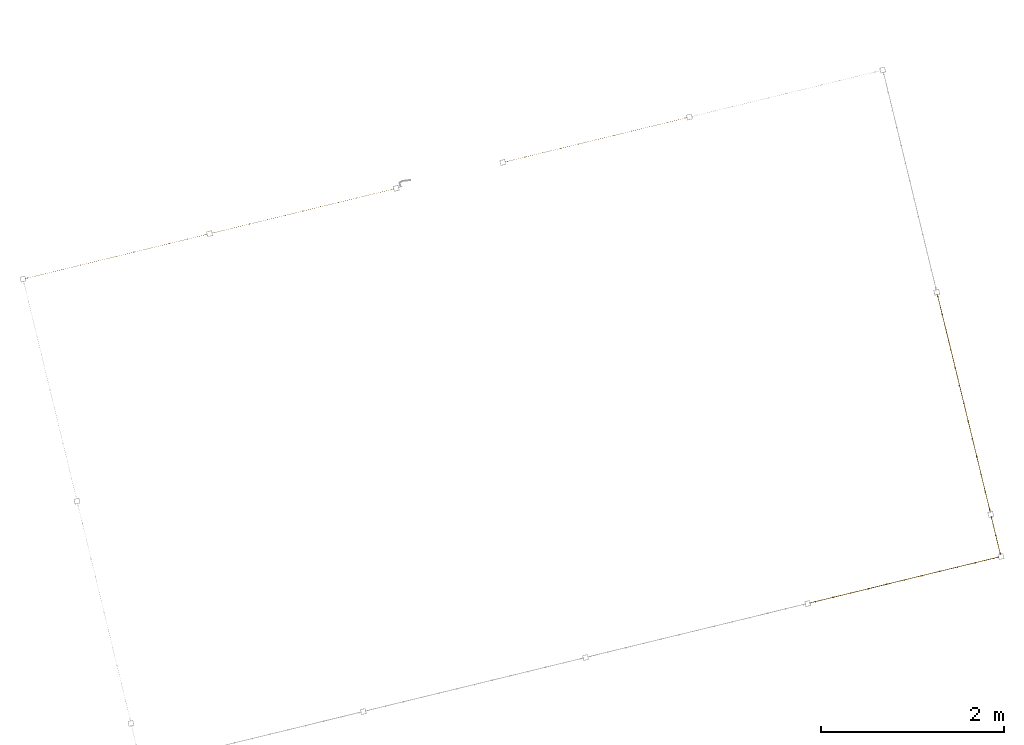
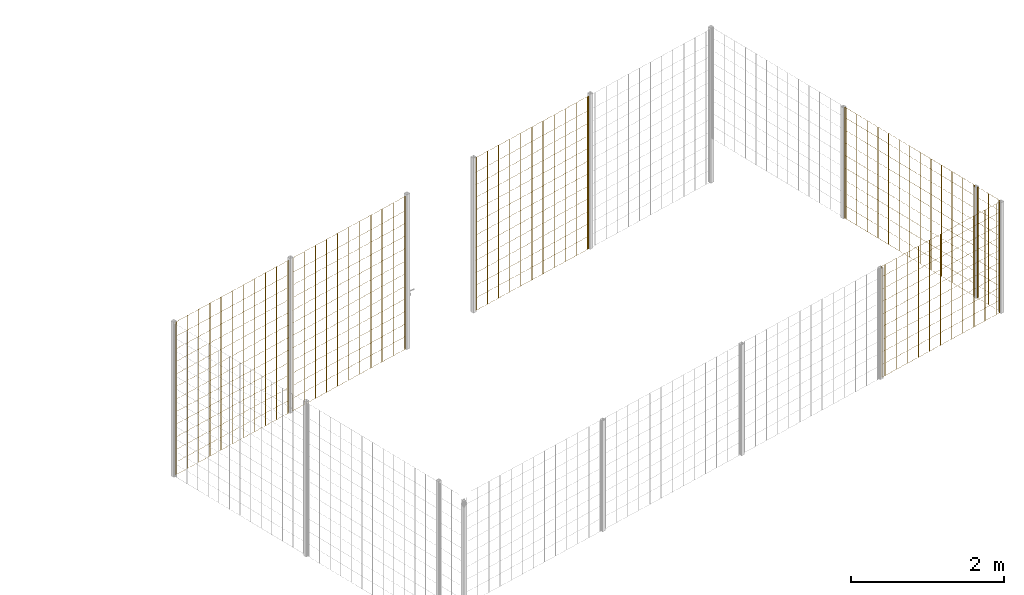
# One storey, part 8 of 10: 6 railings.
"""IFC2X3 building model written with IfcOpenShell, lengths in millimetres."""

from ifc_helpers import new_model, entity, si_unit, converted_unit, derived_unit, direction, frame, origin, origin_2d_with_axis, place, context, subcontext, project, spatial, rectangle, circle, extrude, material, material_list, element, save


model = new_model("IFC2X3")

# Units and contexts
model_context = context("Model", 3, precision=0.01, world=origin(), true_north=direction((6.12303176911189e-17, 1.0)))
body_context = subcontext(model_context, "Body", "Model", "MODEL_VIEW")
ifc_project = project(units=[si_unit("LENGTHUNIT", "METRE", prefix="MILLI"), si_unit("AREAUNIT", "SQUARE_METRE"), si_unit("VOLUMEUNIT", "CUBIC_METRE"), converted_unit("PLANEANGLEUNIT", "DEGREE", entity("IfcRatioMeasure", 0.0174532925199433), si_unit("PLANEANGLEUNIT", "RADIAN"), dimensions=[0, 0, 0, 0, 0, 0, 0]), si_unit("MASSUNIT", "GRAM", prefix="KILO"), derived_unit("MASSDENSITYUNIT", [(si_unit("MASSUNIT", "GRAM", prefix="KILO"), 1), (si_unit("LENGTHUNIT", "METRE"), -3)]), derived_unit("MOMENTOFINERTIAUNIT", [(si_unit("LENGTHUNIT", "METRE"), 4)]), si_unit("TIMEUNIT", "SECOND"), si_unit("FREQUENCYUNIT", "HERTZ"), si_unit("THERMODYNAMICTEMPERATUREUNIT", "DEGREE_CELSIUS"), derived_unit("THERMALTRANSMITTANCEUNIT", [(si_unit("MASSUNIT", "GRAM", prefix="KILO"), 1), (si_unit("THERMODYNAMICTEMPERATUREUNIT", "KELVIN"), -1), (si_unit("TIMEUNIT", "SECOND"), -3)]), derived_unit("VOLUMETRICFLOWRATEUNIT", [(si_unit("LENGTHUNIT", "METRE"), 3), (si_unit("TIMEUNIT", "SECOND"), -1)]), derived_unit("MASSFLOWRATEUNIT", [(si_unit("MASSUNIT", "GRAM", prefix="KILO"), 1), (si_unit("TIMEUNIT", "SECOND"), -1)]), derived_unit("ROTATIONALFREQUENCYUNIT", [(si_unit("TIMEUNIT", "SECOND"), -1)]), si_unit("ELECTRICCURRENTUNIT", "AMPERE"), si_unit("ELECTRICVOLTAGEUNIT", "VOLT"), si_unit("POWERUNIT", "WATT"), si_unit("FORCEUNIT", "NEWTON", prefix="KILO"), si_unit("ILLUMINANCEUNIT", "LUX"), si_unit("LUMINOUSFLUXUNIT", "LUMEN"), si_unit("LUMINOUSINTENSITYUNIT", "CANDELA"), derived_unit("USERDEFINED", [(si_unit("MASSUNIT", "GRAM", prefix="KILO"), -1), (si_unit("LENGTHUNIT", "METRE"), -2), (si_unit("TIMEUNIT", "SECOND"), 3), (si_unit("LUMINOUSFLUXUNIT", "LUMEN"), 1)]), derived_unit("LINEARVELOCITYUNIT", [(si_unit("LENGTHUNIT", "METRE"), 1), (si_unit("TIMEUNIT", "SECOND"), -1)]), si_unit("PRESSUREUNIT", "PASCAL"), derived_unit("USERDEFINED", [(si_unit("LENGTHUNIT", "METRE"), -2), (si_unit("MASSUNIT", "GRAM", prefix="KILO"), 1), (si_unit("TIMEUNIT", "SECOND"), -2)]), derived_unit("LINEARFORCEUNIT", [(si_unit("MASSUNIT", "GRAM", prefix="KILO"), 1), (si_unit("LENGTHUNIT", "METRE"), 1), (si_unit("TIMEUNIT", "SECOND"), -2), (si_unit("LENGTHUNIT", "METRE"), -1)]), derived_unit("PLANARFORCEUNIT", [(si_unit("MASSUNIT", "GRAM", prefix="KILO"), 1), (si_unit("LENGTHUNIT", "METRE"), 1), (si_unit("TIMEUNIT", "SECOND"), -2), (si_unit("LENGTHUNIT", "METRE"), -2)])], contexts=[model_context])

# Site, building, storey
site_placement = place(None, frame((19171.75, -72498.58, 0.0), z_axis=(0.0, 0.0, 1.0), x_axis=(0.971695960795463, 0.236234967296933, 0.0)))
site = spatial("IfcSite", under=ifc_project, at=site_placement, CompositionType="ELEMENT")
building_placement = place(site_placement, origin())
building = spatial("IfcBuilding", under=site, at=building_placement, CompositionType="ELEMENT")
storey_placement = place(building_placement, origin())
storey = spatial("IfcBuildingStorey", under=building, at=storey_placement, Name="01", CompositionType="ELEMENT", Elevation=0.0)

# Railings
ifc_material = material()
ifc_material_list_1 = material_list([ifc_material, ifc_material, ifc_material, ifc_material, ifc_material, ifc_material, ifc_material, ifc_material, ifc_material, ifc_material, ifc_material, ifc_material, ifc_material, ifc_material, ifc_material, ifc_material, ifc_material, ifc_material, ifc_material, ifc_material, ifc_material, ifc_material, ifc_material, ifc_material, ifc_material, ifc_material])
railing_1_placement = place(storey_placement, frame((224.41, 5593.41, 0.0)))
element("IfcRailing", 1, at=railing_1_placement, inside=storey, material=ifc_material_list_1, PredefinedType="NOTDEFINED", context=body_context, shape_type="SweptSolid", body=[
    extrude(circle(Radius=5.0, at=origin_2d_with_axis()), frame((2025.59, 6.59, 2.0), z_axis=(0.0, 0.0, 1.0), x_axis=(0.0, 1.0, 0.0)), (0.0, 0.0, 1.0), 2428.0),
    extrude(circle(Radius=5.0, at=origin_2d_with_axis()), frame((1825.59, 6.59, 2.0), z_axis=(0.0, 0.0, 1.0), x_axis=(0.0, 1.0, 0.0)), (0.0, 0.0, 1.0), 2428.0),
    extrude(circle(Radius=5.0, at=origin_2d_with_axis()), frame((1625.59, 6.59, 2.0), z_axis=(0.0, 0.0, 1.0), x_axis=(0.0, 1.0, 0.0)), (0.0, 0.0, 1.0), 2428.0),
    extrude(circle(Radius=5.0, at=origin_2d_with_axis()), frame((1425.59, 6.59, 2.0), z_axis=(0.0, 0.0, 1.0), x_axis=(0.0, 1.0, 0.0)), (0.0, 0.0, 1.0), 2428.0),
    extrude(circle(Radius=5.0, at=origin_2d_with_axis()), frame((1225.59, 6.59, 2.0), z_axis=(0.0, 0.0, 1.0), x_axis=(0.0, 1.0, 0.0)), (0.0, 0.0, 1.0), 2428.0),
    extrude(circle(Radius=5.0, at=origin_2d_with_axis()), frame((1025.59, 6.59, 2.0), z_axis=(0.0, 0.0, 1.0), x_axis=(0.0, 1.0, 0.0)), (0.0, 0.0, 1.0), 2428.0),
    extrude(circle(Radius=5.0, at=origin_2d_with_axis()), frame((825.59, 6.59, 2.0), z_axis=(0.0, 0.0, 1.0), x_axis=(0.0, 1.0, 0.0)), (0.0, 0.0, 1.0), 2428.0),
    extrude(circle(Radius=5.0, at=origin_2d_with_axis()), frame((625.59, 6.59, 2.0), z_axis=(0.0, 0.0, 1.0), x_axis=(0.0, 1.0, 0.0)), (0.0, 0.0, 1.0), 2428.0),
    extrude(circle(Radius=5.0, at=origin_2d_with_axis()), frame((425.59, 6.59, 2.0), z_axis=(0.0, 0.0, 1.0), x_axis=(0.0, 1.0, 0.0)), (0.0, 0.0, 1.0), 2428.0),
    extrude(circle(Radius=5.0, at=origin_2d_with_axis()), frame((225.59, 6.59, 2.0), z_axis=(0.0, 0.0, 1.0), x_axis=(0.0, 1.0, 0.0)), (0.0, 0.0, 1.0), 2428.0),
    extrude(circle(Radius=5.0, at=origin_2d_with_axis()), frame((25.59, 6.59, 2.0), z_axis=(0.0, 0.0, 1.0), x_axis=(0.0, 1.0, 0.0)), (0.0, 0.0, 1.0), 2428.0),
    extrude(circle(Radius=5.0, at=origin_2d_with_axis()), frame((2044.59, 6.59, 2.0), z_axis=(0.0, 0.0, 1.0), x_axis=(0.0, 1.0, 0.0)), (0.0, 0.0, 1.0), 2428.0),
    extrude(circle(Radius=5.0, at=origin_2d_with_axis()), frame((6.59, 6.59, 2.0), z_axis=(0.0, 0.0, 1.0), x_axis=(0.0, 1.0, 0.0)), (0.0, 0.0, 1.0), 2428.0),
    extrude(rectangle(XDim=2037.99999999998, YDim=1.99999999999955, at=origin_2d_with_axis()), frame((1025.59, 5.59, 0.0)), (0.0, 0.0, 1.0), 2.00000000000043),
    extrude(rectangle(XDim=2037.99999999998, YDim=1.99999999999955, at=origin_2d_with_axis()), frame((1025.59, 5.59, 200.0)), (0.0, 0.0, 1.0), 2.00000000000043),
    extrude(rectangle(XDim=2037.99999999998, YDim=1.99999999999955, at=origin_2d_with_axis()), frame((1025.59, 5.59, 400.0)), (0.0, 0.0, 1.0), 2.00000000000043),
    extrude(rectangle(XDim=2037.99999999998, YDim=1.99999999999955, at=origin_2d_with_axis()), frame((1025.59, 5.59, 600.0)), (0.0, 0.0, 1.0), 2.00000000000043),
    extrude(rectangle(XDim=2037.99999999998, YDim=1.99999999999955, at=origin_2d_with_axis()), frame((1025.59, 5.59, 800.0)), (0.0, 0.0, 1.0), 2.00000000000036),
    extrude(rectangle(XDim=2037.99999999998, YDim=1.99999999999955, at=origin_2d_with_axis()), frame((1025.59, 5.59, 1000.0)), (0.0, 0.0, 1.0), 2.00000000000036),
    extrude(rectangle(XDim=2037.99999999998, YDim=1.99999999999955, at=origin_2d_with_axis()), frame((1025.59, 5.59, 1200.0)), (0.0, 0.0, 1.0), 2.00000000000036),
    extrude(rectangle(XDim=2037.99999999998, YDim=1.99999999999955, at=origin_2d_with_axis()), frame((1025.59, 5.59, 1400.0)), (0.0, 0.0, 1.0), 2.00000000000036),
    extrude(rectangle(XDim=2037.99999999998, YDim=1.99999999999955, at=origin_2d_with_axis()), frame((1025.59, 5.59, 1600.0)), (0.0, 0.0, 1.0), 2.00000000000036),
    extrude(rectangle(XDim=2037.99999999998, YDim=1.99999999999955, at=origin_2d_with_axis()), frame((1025.59, 5.59, 1800.0)), (0.0, 0.0, 1.0), 2.00000000000036),
    extrude(rectangle(XDim=2037.99999999998, YDim=1.99999999999955, at=origin_2d_with_axis()), frame((1025.59, 5.59, 2000.0)), (0.0, 0.0, 1.0), 2.00000000000036),
    extrude(rectangle(XDim=2037.99999999998, YDim=1.99999999999955, at=origin_2d_with_axis()), frame((1025.59, 5.59, 2200.0)), (0.0, 0.0, 1.0), 2.00000000000036),
    extrude(rectangle(XDim=2037.99999999998, YDim=1.99999999999955, at=origin_2d_with_axis()), frame((1025.59, 5.59, 2430.0)), (0.0, 0.0, 1.0), 2.00000000000036),
])
railing_2_placement = place(storey_placement, frame((2324.41, 5593.41, 0.0)))
element("IfcRailing", 2, at=railing_2_placement, inside=storey, material=ifc_material_list_1, PredefinedType="NOTDEFINED", context=body_context, shape_type="SweptSolid", body=[
    extrude(circle(Radius=5.0, at=origin_2d_with_axis()), frame((2025.59, 6.59, 2.0), z_axis=(0.0, 0.0, 1.0), x_axis=(0.0, 1.0, 0.0)), (0.0, 0.0, 1.0), 2428.0),
    extrude(circle(Radius=5.0, at=origin_2d_with_axis()), frame((1825.59, 6.59, 2.0), z_axis=(0.0, 0.0, 1.0), x_axis=(0.0, 1.0, 0.0)), (0.0, 0.0, 1.0), 2428.0),
    extrude(circle(Radius=5.0, at=origin_2d_with_axis()), frame((1625.59, 6.59, 2.0), z_axis=(0.0, 0.0, 1.0), x_axis=(0.0, 1.0, 0.0)), (0.0, 0.0, 1.0), 2428.0),
    extrude(circle(Radius=5.0, at=origin_2d_with_axis()), frame((1425.59, 6.59, 2.0), z_axis=(0.0, 0.0, 1.0), x_axis=(0.0, 1.0, 0.0)), (0.0, 0.0, 1.0), 2428.0),
    extrude(circle(Radius=5.0, at=origin_2d_with_axis()), frame((1225.59, 6.59, 2.0), z_axis=(0.0, 0.0, 1.0), x_axis=(0.0, 1.0, 0.0)), (0.0, 0.0, 1.0), 2428.0),
    extrude(circle(Radius=5.0, at=origin_2d_with_axis()), frame((1025.59, 6.59, 2.0), z_axis=(0.0, 0.0, 1.0), x_axis=(0.0, 1.0, 0.0)), (0.0, 0.0, 1.0), 2428.0),
    extrude(circle(Radius=5.0, at=origin_2d_with_axis()), frame((825.59, 6.59, 2.0), z_axis=(0.0, 0.0, 1.0), x_axis=(0.0, 1.0, 0.0)), (0.0, 0.0, 1.0), 2428.0),
    extrude(circle(Radius=5.0, at=origin_2d_with_axis()), frame((625.59, 6.59, 2.0), z_axis=(0.0, 0.0, 1.0), x_axis=(0.0, 1.0, 0.0)), (0.0, 0.0, 1.0), 2428.0),
    extrude(circle(Radius=5.0, at=origin_2d_with_axis()), frame((425.59, 6.59, 2.0), z_axis=(0.0, 0.0, 1.0), x_axis=(0.0, 1.0, 0.0)), (0.0, 0.0, 1.0), 2428.0),
    extrude(circle(Radius=5.0, at=origin_2d_with_axis()), frame((225.59, 6.59, 2.0), z_axis=(0.0, 0.0, 1.0), x_axis=(0.0, 1.0, 0.0)), (0.0, 0.0, 1.0), 2428.0),
    extrude(circle(Radius=5.0, at=origin_2d_with_axis()), frame((25.59, 6.59, 2.0), z_axis=(0.0, 0.0, 1.0), x_axis=(0.0, 1.0, 0.0)), (0.0, 0.0, 1.0), 2428.0),
    extrude(circle(Radius=5.0, at=origin_2d_with_axis()), frame((2044.59, 6.59, 2.0), z_axis=(0.0, 0.0, 1.0), x_axis=(0.0, 1.0, 0.0)), (0.0, 0.0, 1.0), 2428.0),
    extrude(circle(Radius=5.0, at=origin_2d_with_axis()), frame((6.59, 6.59, 2.0), z_axis=(0.0, 0.0, 1.0), x_axis=(0.0, 1.0, 0.0)), (0.0, 0.0, 1.0), 2428.0),
    extrude(rectangle(XDim=2037.99999999998, YDim=1.99999999999955, at=origin_2d_with_axis()), frame((1025.59, 5.59, 0.0)), (0.0, 0.0, 1.0), 2.00000000000043),
    extrude(rectangle(XDim=2037.99999999998, YDim=1.99999999999955, at=origin_2d_with_axis()), frame((1025.59, 5.59, 200.0)), (0.0, 0.0, 1.0), 2.00000000000043),
    extrude(rectangle(XDim=2037.99999999998, YDim=1.99999999999955, at=origin_2d_with_axis()), frame((1025.59, 5.59, 400.0)), (0.0, 0.0, 1.0), 2.00000000000043),
    extrude(rectangle(XDim=2037.99999999998, YDim=1.99999999999955, at=origin_2d_with_axis()), frame((1025.59, 5.59, 600.0)), (0.0, 0.0, 1.0), 2.00000000000043),
    extrude(rectangle(XDim=2037.99999999998, YDim=1.99999999999955, at=origin_2d_with_axis()), frame((1025.59, 5.59, 800.0)), (0.0, 0.0, 1.0), 2.00000000000036),
    extrude(rectangle(XDim=2037.99999999998, YDim=1.99999999999955, at=origin_2d_with_axis()), frame((1025.59, 5.59, 1000.0)), (0.0, 0.0, 1.0), 2.00000000000036),
    extrude(rectangle(XDim=2037.99999999998, YDim=1.99999999999955, at=origin_2d_with_axis()), frame((1025.59, 5.59, 1200.0)), (0.0, 0.0, 1.0), 2.00000000000036),
    extrude(rectangle(XDim=2037.99999999998, YDim=1.99999999999955, at=origin_2d_with_axis()), frame((1025.59, 5.59, 1400.0)), (0.0, 0.0, 1.0), 2.00000000000036),
    extrude(rectangle(XDim=2037.99999999998, YDim=1.99999999999955, at=origin_2d_with_axis()), frame((1025.59, 5.59, 1600.0)), (0.0, 0.0, 1.0), 2.00000000000036),
    extrude(rectangle(XDim=2037.99999999998, YDim=1.99999999999955, at=origin_2d_with_axis()), frame((1025.59, 5.59, 1800.0)), (0.0, 0.0, 1.0), 2.00000000000036),
    extrude(rectangle(XDim=2037.99999999998, YDim=1.99999999999955, at=origin_2d_with_axis()), frame((1025.59, 5.59, 2000.0)), (0.0, 0.0, 1.0), 2.00000000000036),
    extrude(rectangle(XDim=2037.99999999998, YDim=1.99999999999955, at=origin_2d_with_axis()), frame((1025.59, 5.59, 2200.0)), (0.0, 0.0, 1.0), 2.00000000000036),
    extrude(rectangle(XDim=2037.99999999998, YDim=1.99999999999955, at=origin_2d_with_axis()), frame((1025.59, 5.59, 2430.0)), (0.0, 0.0, 1.0), 2.00000000000036),
])
railing_3_placement = place(storey_placement, frame((5624.41, 5593.41, 0.0)))
element("IfcRailing", 3, at=railing_3_placement, inside=storey, material=ifc_material_list_1, PredefinedType="NOTDEFINED", context=body_context, shape_type="SweptSolid", body=[
    extrude(circle(Radius=5.0, at=origin_2d_with_axis()), frame((2025.59, 6.59, 2.0), z_axis=(0.0, 0.0, 1.0), x_axis=(0.0, 1.0, 0.0)), (0.0, 0.0, 1.0), 2428.0),
    extrude(circle(Radius=5.0, at=origin_2d_with_axis()), frame((1825.59, 6.59, 2.0), z_axis=(0.0, 0.0, 1.0), x_axis=(0.0, 1.0, 0.0)), (0.0, 0.0, 1.0), 2428.0),
    extrude(circle(Radius=5.0, at=origin_2d_with_axis()), frame((1625.59, 6.59, 2.0), z_axis=(0.0, 0.0, 1.0), x_axis=(0.0, 1.0, 0.0)), (0.0, 0.0, 1.0), 2428.0),
    extrude(circle(Radius=5.0, at=origin_2d_with_axis()), frame((1425.59, 6.59, 2.0), z_axis=(0.0, 0.0, 1.0), x_axis=(0.0, 1.0, 0.0)), (0.0, 0.0, 1.0), 2428.0),
    extrude(circle(Radius=5.0, at=origin_2d_with_axis()), frame((1225.59, 6.59, 2.0), z_axis=(0.0, 0.0, 1.0), x_axis=(0.0, 1.0, 0.0)), (0.0, 0.0, 1.0), 2428.0),
    extrude(circle(Radius=5.0, at=origin_2d_with_axis()), frame((1025.59, 6.59, 2.0), z_axis=(0.0, 0.0, 1.0), x_axis=(0.0, 1.0, 0.0)), (0.0, 0.0, 1.0), 2428.0),
    extrude(circle(Radius=5.0, at=origin_2d_with_axis()), frame((825.59, 6.59, 2.0), z_axis=(0.0, 0.0, 1.0), x_axis=(0.0, 1.0, 0.0)), (0.0, 0.0, 1.0), 2428.0),
    extrude(circle(Radius=5.0, at=origin_2d_with_axis()), frame((625.59, 6.59, 2.0), z_axis=(0.0, 0.0, 1.0), x_axis=(0.0, 1.0, 0.0)), (0.0, 0.0, 1.0), 2428.0),
    extrude(circle(Radius=5.0, at=origin_2d_with_axis()), frame((425.59, 6.59, 2.0), z_axis=(0.0, 0.0, 1.0), x_axis=(0.0, 1.0, 0.0)), (0.0, 0.0, 1.0), 2428.0),
    extrude(circle(Radius=5.0, at=origin_2d_with_axis()), frame((225.59, 6.59, 2.0), z_axis=(0.0, 0.0, 1.0), x_axis=(0.0, 1.0, 0.0)), (0.0, 0.0, 1.0), 2428.0),
    extrude(circle(Radius=5.0, at=origin_2d_with_axis()), frame((25.59, 6.59, 2.0), z_axis=(0.0, 0.0, 1.0), x_axis=(0.0, 1.0, 0.0)), (0.0, 0.0, 1.0), 2428.0),
    extrude(circle(Radius=5.0, at=origin_2d_with_axis()), frame((2044.59, 6.59, 2.0), z_axis=(0.0, 0.0, 1.0), x_axis=(0.0, 1.0, 0.0)), (0.0, 0.0, 1.0), 2428.0),
    extrude(circle(Radius=5.0, at=origin_2d_with_axis()), frame((6.59, 6.59, 2.0), z_axis=(0.0, 0.0, 1.0), x_axis=(0.0, 1.0, 0.0)), (0.0, 0.0, 1.0), 2428.0),
    extrude(rectangle(XDim=2037.99999999998, YDim=1.99999999999955, at=origin_2d_with_axis()), frame((1025.59, 5.59, 0.0)), (0.0, 0.0, 1.0), 2.00000000000043),
    extrude(rectangle(XDim=2037.99999999998, YDim=1.99999999999955, at=origin_2d_with_axis()), frame((1025.59, 5.59, 200.0)), (0.0, 0.0, 1.0), 2.00000000000043),
    extrude(rectangle(XDim=2037.99999999998, YDim=1.99999999999955, at=origin_2d_with_axis()), frame((1025.59, 5.59, 400.0)), (0.0, 0.0, 1.0), 2.00000000000043),
    extrude(rectangle(XDim=2037.99999999998, YDim=1.99999999999955, at=origin_2d_with_axis()), frame((1025.59, 5.59, 600.0)), (0.0, 0.0, 1.0), 2.00000000000043),
    extrude(rectangle(XDim=2037.99999999998, YDim=1.99999999999955, at=origin_2d_with_axis()), frame((1025.59, 5.59, 800.0)), (0.0, 0.0, 1.0), 2.00000000000036),
    extrude(rectangle(XDim=2037.99999999998, YDim=1.99999999999955, at=origin_2d_with_axis()), frame((1025.59, 5.59, 1000.0)), (0.0, 0.0, 1.0), 2.00000000000036),
    extrude(rectangle(XDim=2037.99999999998, YDim=1.99999999999955, at=origin_2d_with_axis()), frame((1025.59, 5.59, 1200.0)), (0.0, 0.0, 1.0), 2.00000000000036),
    extrude(rectangle(XDim=2037.99999999998, YDim=1.99999999999955, at=origin_2d_with_axis()), frame((1025.59, 5.59, 1400.0)), (0.0, 0.0, 1.0), 2.00000000000036),
    extrude(rectangle(XDim=2037.99999999998, YDim=1.99999999999955, at=origin_2d_with_axis()), frame((1025.59, 5.59, 1600.0)), (0.0, 0.0, 1.0), 2.00000000000036),
    extrude(rectangle(XDim=2037.99999999998, YDim=1.99999999999955, at=origin_2d_with_axis()), frame((1025.59, 5.59, 1800.0)), (0.0, 0.0, 1.0), 2.00000000000036),
    extrude(rectangle(XDim=2037.99999999998, YDim=1.99999999999955, at=origin_2d_with_axis()), frame((1025.59, 5.59, 2000.0)), (0.0, 0.0, 1.0), 2.00000000000036),
    extrude(rectangle(XDim=2037.99999999998, YDim=1.99999999999955, at=origin_2d_with_axis()), frame((1025.59, 5.59, 2200.0)), (0.0, 0.0, 1.0), 2.00000000000036),
    extrude(rectangle(XDim=2037.99999999998, YDim=1.99999999999955, at=origin_2d_with_axis()), frame((1025.59, 5.59, 2430.0)), (0.0, 0.0, 1.0), 2.00000000000036),
])
ifc_material_list_2 = material_list([ifc_material, ifc_material, ifc_material, ifc_material, ifc_material, ifc_material, ifc_material, ifc_material, ifc_material, ifc_material, ifc_material, ifc_material, ifc_material, ifc_material, ifc_material, ifc_material, ifc_material, ifc_material, ifc_material, ifc_material, ifc_material, ifc_material, ifc_material, ifc_material, ifc_material])
railing_4_placement = place(storey_placement, frame((9868.41, 619.51, 700.0)))
element("IfcRailing", 4, at=railing_4_placement, inside=storey, material=ifc_material_list_2, Name=": 2", ObjectType=": 2", PredefinedType="NOTDEFINED", context=body_context, shape_type="SweptSolid", body=[
    extrude(circle(Radius=5.0, at=origin_2d_with_axis()), frame((6.59, 2429.79, 2.0), z_axis=(0.0, 0.0, 1.0), x_axis=(-1.0, 0.0, 0.0)), (0.0, 0.0, 1.0), 1763.0),
    extrude(circle(Radius=5.0, at=origin_2d_with_axis()), frame((6.59, 2229.79, 2.0), z_axis=(0.0, 0.0, 1.0), x_axis=(-1.0, 0.0, 0.0)), (0.0, 0.0, 1.0), 1763.0),
    extrude(circle(Radius=5.0, at=origin_2d_with_axis()), frame((6.59, 2029.79, 2.0), z_axis=(0.0, 0.0, 1.0), x_axis=(-1.0, 0.0, 0.0)), (0.0, 0.0, 1.0), 1763.0),
    extrude(circle(Radius=5.0, at=origin_2d_with_axis()), frame((6.59, 1829.79, 2.0), z_axis=(0.0, 0.0, 1.0), x_axis=(-1.0, 0.0, 0.0)), (0.0, 0.0, 1.0), 1763.0),
    extrude(circle(Radius=5.0, at=origin_2d_with_axis()), frame((6.59, 1629.79, 2.0), z_axis=(0.0, 0.0, 1.0), x_axis=(-1.0, 0.0, 0.0)), (0.0, 0.0, 1.0), 1763.0),
    extrude(circle(Radius=5.0, at=origin_2d_with_axis()), frame((6.59, 1429.79, 2.0), z_axis=(0.0, 0.0, 1.0), x_axis=(-1.0, 0.0, 0.0)), (0.0, 0.0, 1.0), 1763.0),
    extrude(circle(Radius=5.0, at=origin_2d_with_axis()), frame((6.59, 1229.79, 2.0), z_axis=(0.0, 0.0, 1.0), x_axis=(-1.0, 0.0, 0.0)), (0.0, 0.0, 1.0), 1763.0),
    extrude(circle(Radius=5.0, at=origin_2d_with_axis()), frame((6.59, 1029.79, 2.0), z_axis=(0.0, 0.0, 1.0), x_axis=(-1.0, 0.0, 0.0)), (0.0, 0.0, 1.0), 1763.0),
    extrude(circle(Radius=5.0, at=origin_2d_with_axis()), frame((6.59, 829.79, 2.0), z_axis=(0.0, 0.0, 1.0), x_axis=(-1.0, 0.0, 0.0)), (0.0, 0.0, 1.0), 1763.0),
    extrude(circle(Radius=5.0, at=origin_2d_with_axis()), frame((6.59, 629.79, 2.0), z_axis=(0.0, 0.0, 1.0), x_axis=(-1.0, 0.0, 0.0)), (0.0, 0.0, 1.0), 1763.0),
    extrude(circle(Radius=5.0, at=origin_2d_with_axis()), frame((6.59, 429.79, 2.0), z_axis=(0.0, 0.0, 1.0), x_axis=(-1.0, 0.0, 0.0)), (0.0, 0.0, 1.0), 1763.0),
    extrude(circle(Radius=5.0, at=origin_2d_with_axis()), frame((6.59, 229.79, 2.0), z_axis=(0.0, 0.0, 1.0), x_axis=(-1.0, 0.0, 0.0)), (0.0, 0.0, 1.0), 1763.0),
    extrude(circle(Radius=5.0, at=origin_2d_with_axis()), frame((6.59, 29.79, 2.0), z_axis=(0.0, 0.0, 1.0), x_axis=(-1.0, 0.0, 0.0)), (0.0, 0.0, 1.0), 1763.0),
    extrude(circle(Radius=5.0, at=origin_2d_with_axis()), frame((6.59, 2452.99, 2.0), z_axis=(0.0, 0.0, 1.0), x_axis=(-1.0, 0.0, 0.0)), (0.0, 0.0, 1.0), 1763.0),
    extrude(circle(Radius=5.0, at=origin_2d_with_axis()), frame((6.59, 6.59, 2.0), z_axis=(0.0, 0.0, 1.0), x_axis=(-1.0, 0.0, 0.0)), (0.0, 0.0, 1.0), 1763.0),
    extrude(rectangle(XDim=2446.4, YDim=1.99999999999955, at=origin_2d_with_axis()), frame((7.59, 1229.79, 0.0), z_axis=(0.0, 0.0, 1.0), x_axis=(0.0, 1.0, 0.0)), (0.0, 0.0, 1.0), 2.00000000000036),
    extrude(rectangle(XDim=2446.4, YDim=1.99999999999955, at=origin_2d_with_axis()), frame((7.59, 1229.79, 200.0), z_axis=(0.0, 0.0, 1.0), x_axis=(0.0, 1.0, 0.0)), (0.0, 0.0, 1.0), 2.00000000000036),
    extrude(rectangle(XDim=2446.4, YDim=1.99999999999955, at=origin_2d_with_axis()), frame((7.59, 1229.79, 400.0), z_axis=(0.0, 0.0, 1.0), x_axis=(0.0, 1.0, 0.0)), (0.0, 0.0, 1.0), 2.00000000000036),
    extrude(rectangle(XDim=2446.4, YDim=1.99999999999955, at=origin_2d_with_axis()), frame((7.59, 1229.79, 600.0), z_axis=(0.0, 0.0, 1.0), x_axis=(0.0, 1.0, 0.0)), (0.0, 0.0, 1.0), 2.00000000000036),
    extrude(rectangle(XDim=2446.4, YDim=1.99999999999955, at=origin_2d_with_axis()), frame((7.59, 1229.79, 800.0), z_axis=(0.0, 0.0, 1.0), x_axis=(0.0, 1.0, 0.0)), (0.0, 0.0, 1.0), 2.00000000000036),
    extrude(rectangle(XDim=2446.4, YDim=1.99999999999955, at=origin_2d_with_axis()), frame((7.59, 1229.79, 1000.0), z_axis=(0.0, 0.0, 1.0), x_axis=(0.0, 1.0, 0.0)), (0.0, 0.0, 1.0), 2.00000000000036),
    extrude(rectangle(XDim=2446.4, YDim=1.99999999999955, at=origin_2d_with_axis()), frame((7.59, 1229.79, 1200.0), z_axis=(0.0, 0.0, 1.0), x_axis=(0.0, 1.0, 0.0)), (0.0, 0.0, 1.0), 2.00000000000036),
    extrude(rectangle(XDim=2446.4, YDim=1.99999999999955, at=origin_2d_with_axis()), frame((7.59, 1229.79, 1400.0), z_axis=(0.0, 0.0, 1.0), x_axis=(0.0, 1.0, 0.0)), (0.0, 0.0, 1.0), 2.00000000000036),
    extrude(rectangle(XDim=2446.4, YDim=1.99999999999955, at=origin_2d_with_axis()), frame((7.59, 1229.79, 1600.0), z_axis=(0.0, 0.0, 1.0), x_axis=(0.0, 1.0, 0.0)), (0.0, 0.0, 1.0), 2.00000000000036),
    extrude(rectangle(XDim=2446.4, YDim=1.99999999999955, at=origin_2d_with_axis()), frame((7.59, 1229.79, 1765.0), z_axis=(0.0, 0.0, 1.0), x_axis=(0.0, 1.0, 0.0)), (0.0, 0.0, 1.0), 2.00000000000063),
])
ifc_material_list_3 = material_list([ifc_material, ifc_material, ifc_material, ifc_material, ifc_material, ifc_material, ifc_material, ifc_material, ifc_material, ifc_material, ifc_material, ifc_material, ifc_material, ifc_material, ifc_material])
railing_5_placement = place(storey_placement, frame((9868.41, 145.91, 700.0)))
element("IfcRailing", 5, at=railing_5_placement, inside=storey, material=ifc_material_list_3, Name=": 2", ObjectType=": 2", PredefinedType="NOTDEFINED", context=body_context, shape_type="SweptSolid", body=[
    extrude(circle(Radius=5.0, at=origin_2d_with_axis()), frame((6.59, 16.59, 2.0)), (0.0, 0.0, 1.0), 1763.0),
    extrude(circle(Radius=5.0, at=origin_2d_with_axis()), frame((6.59, 216.59, 2.0)), (0.0, 0.0, 1.0), 1763.0),
    extrude(circle(Radius=5.0, at=origin_2d_with_axis()), frame((6.59, 416.59, 2.0)), (0.0, 0.0, 1.0), 1763.0),
    extrude(circle(Radius=5.0, at=origin_2d_with_axis()), frame((6.59, 6.59, 2.0)), (0.0, 0.0, 1.0), 1763.0),
    extrude(circle(Radius=5.0, at=origin_2d_with_axis()), frame((6.59, 426.59, 2.0)), (0.0, 0.0, 1.0), 1763.0),
    extrude(rectangle(XDim=420.000000000001, YDim=1.99999999999955, at=origin_2d_with_axis()), frame((5.59, 216.59, 0.0), z_axis=(0.0, 0.0, 1.0), x_axis=(0.0, -1.0, 0.0)), (0.0, 0.0, 1.0), 2.00000000000036),
    extrude(rectangle(XDim=420.000000000001, YDim=1.99999999999955, at=origin_2d_with_axis()), frame((5.59, 216.59, 200.0), z_axis=(0.0, 0.0, 1.0), x_axis=(0.0, -1.0, 0.0)), (0.0, 0.0, 1.0), 2.00000000000036),
    extrude(rectangle(XDim=420.000000000001, YDim=1.99999999999955, at=origin_2d_with_axis()), frame((5.59, 216.59, 400.0), z_axis=(0.0, 0.0, 1.0), x_axis=(0.0, -1.0, 0.0)), (0.0, 0.0, 1.0), 2.00000000000036),
    extrude(rectangle(XDim=420.000000000001, YDim=1.99999999999955, at=origin_2d_with_axis()), frame((5.59, 216.59, 600.0), z_axis=(0.0, 0.0, 1.0), x_axis=(0.0, -1.0, 0.0)), (0.0, 0.0, 1.0), 2.00000000000036),
    extrude(rectangle(XDim=420.000000000001, YDim=1.99999999999955, at=origin_2d_with_axis()), frame((5.59, 216.59, 800.0), z_axis=(0.0, 0.0, 1.0), x_axis=(0.0, -1.0, 0.0)), (0.0, 0.0, 1.0), 2.00000000000036),
    extrude(rectangle(XDim=420.000000000001, YDim=1.99999999999955, at=origin_2d_with_axis()), frame((5.59, 216.59, 1000.0), z_axis=(0.0, 0.0, 1.0), x_axis=(0.0, -1.0, 0.0)), (0.0, 0.0, 1.0), 2.00000000000036),
    extrude(rectangle(XDim=420.000000000001, YDim=1.99999999999955, at=origin_2d_with_axis()), frame((5.59, 216.59, 1200.0), z_axis=(0.0, 0.0, 1.0), x_axis=(0.0, -1.0, 0.0)), (0.0, 0.0, 1.0), 2.00000000000036),
    extrude(rectangle(XDim=420.000000000001, YDim=1.99999999999955, at=origin_2d_with_axis()), frame((5.59, 216.59, 1400.0), z_axis=(0.0, 0.0, 1.0), x_axis=(0.0, -1.0, 0.0)), (0.0, 0.0, 1.0), 2.00000000000036),
    extrude(rectangle(XDim=420.000000000001, YDim=1.99999999999955, at=origin_2d_with_axis()), frame((5.59, 216.59, 1600.0), z_axis=(0.0, 0.0, 1.0), x_axis=(0.0, -1.0, 0.0)), (0.0, 0.0, 1.0), 2.00000000000036),
    extrude(rectangle(XDim=420.000000000001, YDim=1.99999999999955, at=origin_2d_with_axis()), frame((5.59, 216.59, 1765.0), z_axis=(0.0, 0.0, 1.0), x_axis=(0.0, -1.0, 0.0)), (0.0, 0.0, 1.0), 2.00000000000063),
])
ifc_material_list_4 = material_list([ifc_material, ifc_material, ifc_material, ifc_material, ifc_material, ifc_material, ifc_material, ifc_material, ifc_material, ifc_material, ifc_material, ifc_material, ifc_material, ifc_material, ifc_material, ifc_material, ifc_material, ifc_material, ifc_material, ifc_material, ifc_material, ifc_material, ifc_material])
railing_6_placement = place(storey_placement, frame((7720.91, 118.41, 700.0)))
element("IfcRailing", 6, at=railing_6_placement, inside=storey, material=ifc_material_list_4, Name=": 2", ObjectType=": 2", PredefinedType="NOTDEFINED", context=body_context, shape_type="SweptSolid", body=[
    extrude(circle(Radius=5.0, at=origin_2d_with_axis()), frame((64.84, 6.59, 2.0), z_axis=(0.0, 0.0, 1.0), x_axis=(0.0, -1.0, 0.0)), (0.0, 0.0, 1.0), 1763.0),
    extrude(circle(Radius=5.0, at=origin_2d_with_axis()), frame((264.84, 6.59, 2.0), z_axis=(0.0, 0.0, 1.0), x_axis=(0.0, -1.0, 0.0)), (0.0, 0.0, 1.0), 1763.0),
    extrude(circle(Radius=5.0, at=origin_2d_with_axis()), frame((464.84, 6.59, 2.0), z_axis=(0.0, 0.0, 1.0), x_axis=(0.0, -1.0, 0.0)), (0.0, 0.0, 1.0), 1763.0),
    extrude(circle(Radius=5.0, at=origin_2d_with_axis()), frame((664.84, 6.59, 2.0), z_axis=(0.0, 0.0, 1.0), x_axis=(0.0, -1.0, 0.0)), (0.0, 0.0, 1.0), 1763.0),
    extrude(circle(Radius=5.0, at=origin_2d_with_axis()), frame((864.84, 6.59, 2.0), z_axis=(0.0, 0.0, 1.0), x_axis=(0.0, -1.0, 0.0)), (0.0, 0.0, 1.0), 1763.0),
    extrude(circle(Radius=5.0, at=origin_2d_with_axis()), frame((1064.84, 6.59, 2.0), z_axis=(0.0, 0.0, 1.0), x_axis=(0.0, -1.0, 0.0)), (0.0, 0.0, 1.0), 1763.0),
    extrude(circle(Radius=5.0, at=origin_2d_with_axis()), frame((1264.84, 6.59, 2.0), z_axis=(0.0, 0.0, 1.0), x_axis=(0.0, -1.0, 0.0)), (0.0, 0.0, 1.0), 1763.0),
    extrude(circle(Radius=5.0, at=origin_2d_with_axis()), frame((1464.84, 6.59, 2.0), z_axis=(0.0, 0.0, 1.0), x_axis=(0.0, -1.0, 0.0)), (0.0, 0.0, 1.0), 1763.0),
    extrude(circle(Radius=5.0, at=origin_2d_with_axis()), frame((1664.84, 6.59, 2.0), z_axis=(0.0, 0.0, 1.0), x_axis=(0.0, -1.0, 0.0)), (0.0, 0.0, 1.0), 1763.0),
    extrude(circle(Radius=5.0, at=origin_2d_with_axis()), frame((1864.84, 6.59, 2.0), z_axis=(0.0, 0.0, 1.0), x_axis=(0.0, -1.0, 0.0)), (0.0, 0.0, 1.0), 1763.0),
    extrude(circle(Radius=5.0, at=origin_2d_with_axis()), frame((2064.84, 6.59, 2.0), z_axis=(0.0, 0.0, 1.0), x_axis=(0.0, -1.0, 0.0)), (0.0, 0.0, 1.0), 1763.0),
    extrude(circle(Radius=5.0, at=origin_2d_with_axis()), frame((6.59, 6.59, 2.0), z_axis=(0.0, 0.0, 1.0), x_axis=(0.0, -1.0, 0.0)), (0.0, 0.0, 1.0), 1763.0),
    extrude(circle(Radius=5.0, at=origin_2d_with_axis()), frame((2123.09, 6.59, 2.0), z_axis=(0.0, 0.0, 1.0), x_axis=(0.0, -1.0, 0.0)), (0.0, 0.0, 1.0), 1763.0),
    extrude(rectangle(XDim=2116.49999999998, YDim=1.99999999999988, at=origin_2d_with_axis()), frame((1064.84, 7.59, 0.0), z_axis=(0.0, 0.0, 1.0), x_axis=(-1.0, 0.0, 0.0)), (0.0, 0.0, 1.0), 2.00000000000036),
    extrude(rectangle(XDim=2116.49999999998, YDim=1.99999999999988, at=origin_2d_with_axis()), frame((1064.84, 7.59, 200.0), z_axis=(0.0, 0.0, 1.0), x_axis=(-1.0, 0.0, 0.0)), (0.0, 0.0, 1.0), 2.00000000000036),
    extrude(rectangle(XDim=2116.49999999998, YDim=1.99999999999988, at=origin_2d_with_axis()), frame((1064.84, 7.59, 400.0), z_axis=(0.0, 0.0, 1.0), x_axis=(-1.0, 0.0, 0.0)), (0.0, 0.0, 1.0), 2.00000000000036),
    extrude(rectangle(XDim=2116.49999999998, YDim=1.99999999999988, at=origin_2d_with_axis()), frame((1064.84, 7.59, 600.0), z_axis=(0.0, 0.0, 1.0), x_axis=(-1.0, 0.0, 0.0)), (0.0, 0.0, 1.0), 2.00000000000036),
    extrude(rectangle(XDim=2116.49999999998, YDim=1.99999999999988, at=origin_2d_with_axis()), frame((1064.84, 7.59, 800.0), z_axis=(0.0, 0.0, 1.0), x_axis=(-1.0, 0.0, 0.0)), (0.0, 0.0, 1.0), 2.00000000000036),
    extrude(rectangle(XDim=2116.49999999998, YDim=1.99999999999988, at=origin_2d_with_axis()), frame((1064.84, 7.59, 1000.0), z_axis=(0.0, 0.0, 1.0), x_axis=(-1.0, 0.0, 0.0)), (0.0, 0.0, 1.0), 2.00000000000036),
    extrude(rectangle(XDim=2116.49999999998, YDim=1.99999999999988, at=origin_2d_with_axis()), frame((1064.84, 7.59, 1200.0), z_axis=(0.0, 0.0, 1.0), x_axis=(-1.0, 0.0, 0.0)), (0.0, 0.0, 1.0), 2.00000000000036),
    extrude(rectangle(XDim=2116.49999999998, YDim=1.99999999999988, at=origin_2d_with_axis()), frame((1064.84, 7.59, 1400.0), z_axis=(0.0, 0.0, 1.0), x_axis=(-1.0, 0.0, 0.0)), (0.0, 0.0, 1.0), 2.00000000000036),
    extrude(rectangle(XDim=2116.49999999998, YDim=1.99999999999988, at=origin_2d_with_axis()), frame((1064.84, 7.59, 1600.0), z_axis=(0.0, 0.0, 1.0), x_axis=(-1.0, 0.0, 0.0)), (0.0, 0.0, 1.0), 2.00000000000036),
    extrude(rectangle(XDim=2116.49999999998, YDim=1.99999999999988, at=origin_2d_with_axis()), frame((1064.84, 7.59, 1765.0), z_axis=(0.0, 0.0, 1.0), x_axis=(-1.0, 0.0, 0.0)), (0.0, 0.0, 1.0), 2.00000000000063),
])

save(model, "model.ifc")
